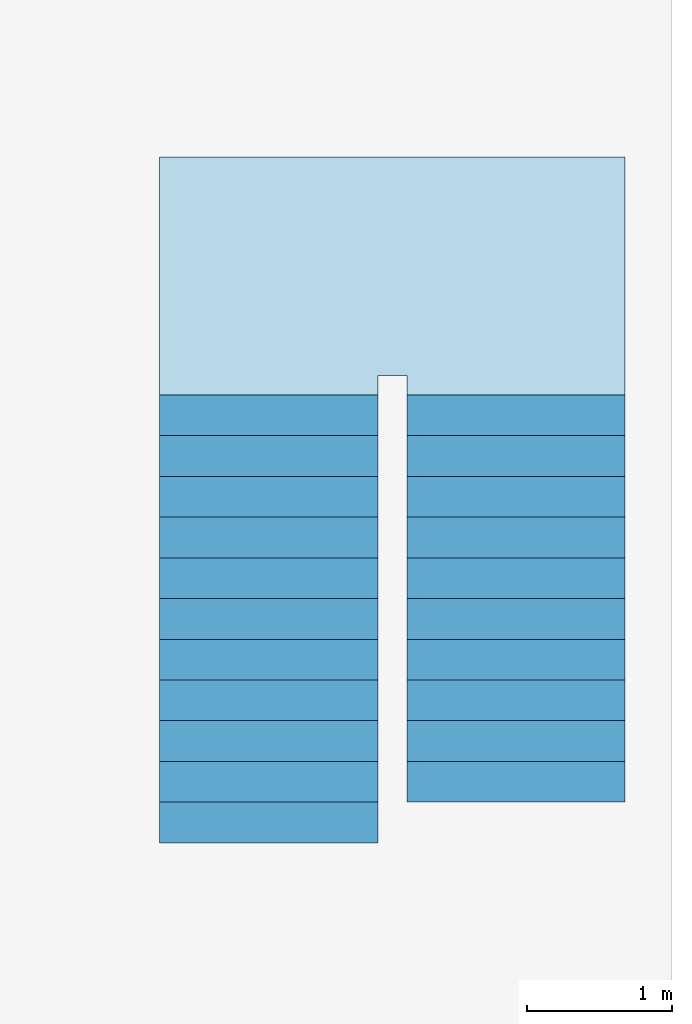
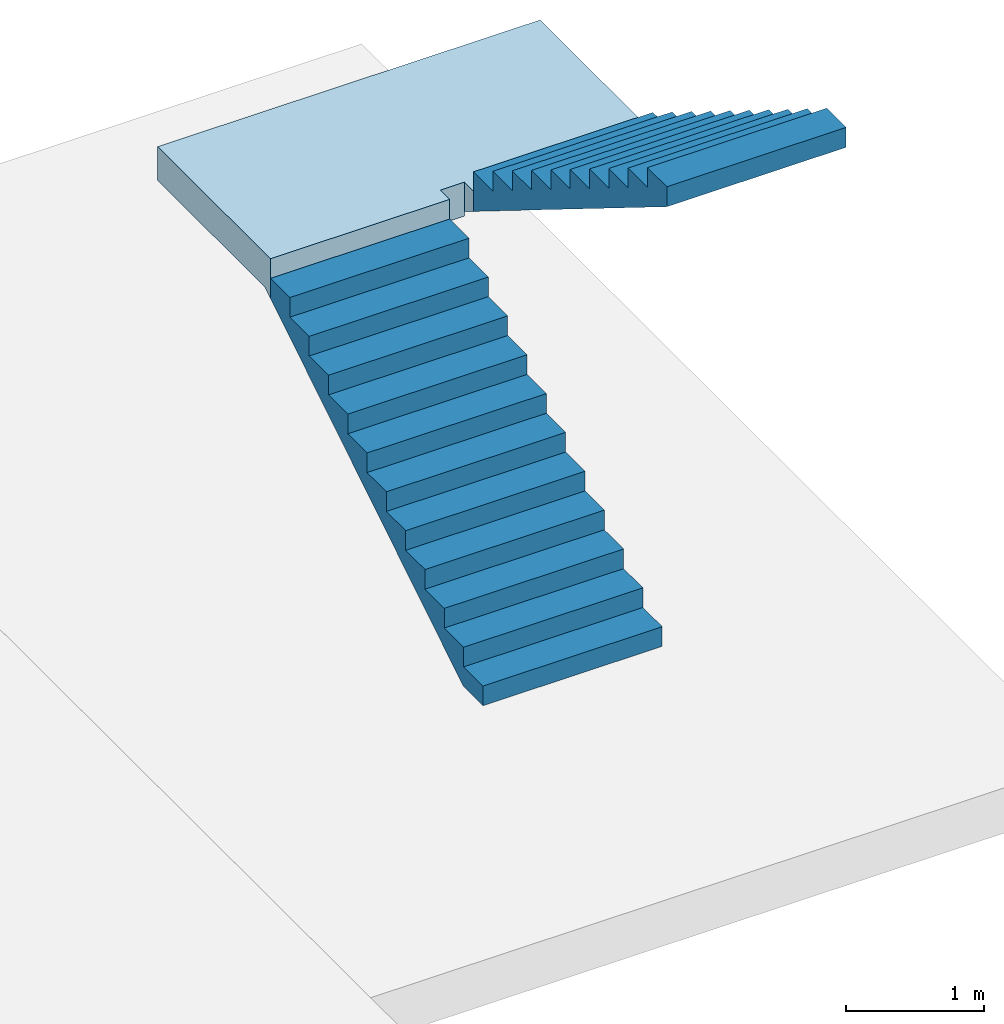
# One storey, part 2 of 2: 2 stair flights, 1 slab, 1 element without a shape of its own.
"""IFC2X3 building model written with IfcOpenShell, lengths in millimetres."""

from ifc_helpers import new_model, entity, si_unit, converted_unit, derived_unit, direction, frame, origin, place, context, subcontext, project, spatial, faceted_brep, material, element, aggregate, save


model = new_model("IFC2X3")

# Units and contexts
model_context = context("Model", 3, precision=0.01, world=origin(), true_north=direction((6.12303176911189e-17, 1.0)))
body_context = subcontext(model_context, "Body", "Model", "MODEL_VIEW")
ifc_project = project(units=[si_unit("LENGTHUNIT", "METRE", prefix="MILLI"), si_unit("AREAUNIT", "SQUARE_METRE"), si_unit("VOLUMEUNIT", "CUBIC_METRE"), converted_unit("PLANEANGLEUNIT", "DEGREE", entity("IfcRatioMeasure", 0.0174532925199433), si_unit("PLANEANGLEUNIT", "RADIAN"), dimensions=[0, 0, 0, 0, 0, 0, 0]), si_unit("MASSUNIT", "GRAM", prefix="KILO"), derived_unit("MASSDENSITYUNIT", [(si_unit("MASSUNIT", "GRAM", prefix="KILO"), 1), (si_unit("LENGTHUNIT", "METRE"), -3)]), si_unit("TIMEUNIT", "SECOND"), si_unit("FREQUENCYUNIT", "HERTZ"), si_unit("THERMODYNAMICTEMPERATUREUNIT", "DEGREE_CELSIUS"), derived_unit("THERMALTRANSMITTANCEUNIT", [(si_unit("MASSUNIT", "GRAM", prefix="KILO"), 1), (si_unit("THERMODYNAMICTEMPERATUREUNIT", "KELVIN"), -1), (si_unit("TIMEUNIT", "SECOND"), -3)]), derived_unit("VOLUMETRICFLOWRATEUNIT", [(si_unit("LENGTHUNIT", "METRE"), 3), (si_unit("TIMEUNIT", "SECOND"), -1)]), si_unit("ELECTRICCURRENTUNIT", "AMPERE"), si_unit("ELECTRICVOLTAGEUNIT", "VOLT"), si_unit("POWERUNIT", "WATT"), si_unit("FORCEUNIT", "NEWTON", prefix="KILO"), si_unit("ILLUMINANCEUNIT", "LUX"), si_unit("LUMINOUSFLUXUNIT", "LUMEN"), si_unit("LUMINOUSINTENSITYUNIT", "CANDELA"), derived_unit("USERDEFINED", [(si_unit("MASSUNIT", "GRAM", prefix="KILO"), -1), (si_unit("LENGTHUNIT", "METRE"), -2), (si_unit("TIMEUNIT", "SECOND"), 3), (si_unit("LUMINOUSFLUXUNIT", "LUMEN"), 1)]), derived_unit("LINEARVELOCITYUNIT", [(si_unit("LENGTHUNIT", "METRE"), 1), (si_unit("TIMEUNIT", "SECOND"), -1)]), si_unit("PRESSUREUNIT", "PASCAL"), derived_unit("USERDEFINED", [(si_unit("LENGTHUNIT", "METRE"), -2), (si_unit("MASSUNIT", "GRAM", prefix="KILO"), 1), (si_unit("TIMEUNIT", "SECOND"), -2)])], contexts=[model_context])

# Site, building, storey
site_placement = place(None, origin())
site = spatial("IfcSite", under=ifc_project, at=site_placement, CompositionType="ELEMENT")
building_placement = place(site_placement, origin())
building = spatial("IfcBuilding", under=site, at=building_placement, CompositionType="ELEMENT")
storey_placement = place(building_placement, origin())
storey = spatial("IfcBuildingStorey", under=building, at=storey_placement, Name="00 Ground level", CompositionType="ELEMENT", Elevation=0.0)

# Stair, slab, stair flights
stair_placement = place(storey_placement, origin())
stair = element("IfcStair", 1, at=stair_placement, inside=storey, Name="Cast-In-Place Stair:Stair", ObjectType="Cast-In-Place Stair:Monolithic Stair", ShapeType="NOTDEFINED")
ifc_material = material(Name="Concrete, Cast In Situ")
slab_placement = place(stair_placement, frame((31263.4900708518, -68480.8241905963, 0.0)))
slab = element("IfcSlab", 2, at=slab_placement, material=ifc_material, Name="Cast-In-Place Stair:Stair:392864 Landing 1", ObjectType="Monolithic Landing:300mm Thickness", PredefinedType="LANDING", context=body_context, shape_type="Brep", body=[
    faceted_brep([(0.0, 0.0, 2086.95652173913), (1500.0, 0.0, 2086.95652173913), (1500.0, 81.2925429905189, 2086.95652173913), (1500.0, 135.0, 2086.95652173913), (1700.0, 135.0, 2086.95652173913), (1700.0, 0.0, 2086.95652173913), (3200.0, 0.0, 2086.95652173913), (3200.0, 198.707457009539, 2086.95652173913), (3200.0, 1635.0, 2086.95652173913), (0.0, 1635.0, 2086.95652173913), (0.0, 81.2925429905189, 2086.95652173913), (0.0, 0.0, 1913.04347826087), (0.0, 0.0, 1736.46425901212), (1500.0, 0.0, 1736.46425901212), (1500.0, 0.0, 1913.04347826087), (1500.0, 81.2925429905189, 1786.95652173913), (1500.0, 135.0, 1786.95652173913), (1700.0, 135.0, 1786.95652173913), (1700.0, 135.0, 1826.52637081337), (3200.0, 0.0, 1910.37730249039), (3200.0, 198.70745700953, 1786.95652173913), (3200.0, 1635.0, 1786.95652173913), (0.0, 1635.0, 1786.95652173913), (0.0, 81.2925429905189, 1786.95652173913), (1700.0, 198.70745700953, 1786.95652173913), (1700.0, 0.0, 1910.37730249039)], [[[0, 1, 2, 3, 4, 5, 6, 7, 8, 9, 10]], [[1, 0, 11, 12, 13, 14]], [[1, 14, 13, 15, 16, 3, 2]], [[4, 3, 16, 17, 18]], [[6, 19, 20, 21, 8, 7]], [[9, 8, 21, 22]], [[12, 11, 0, 10, 9, 22, 23]], [[24, 17, 16, 15, 23, 22, 21, 20]], [[17, 24, 18]], [[23, 15, 13, 12]], [[24, 20, 19, 25, 18]], [[5, 4, 18, 25]], [[6, 5, 25, 19]]]),
])
stair_flight_1_placement = place(stair_placement, frame((31263.4900708518, -71560.8241905963, 0.0)))
stair_flight_1 = element("IfcStairFlight", 3, at=stair_flight_1_placement, material=ifc_material, Name="Cast-In-Place Stair:Stair:392864 Run 1", ObjectType="Monolithic Run:150mm Depth", NumberOfRiser=12, NumberOfTreads=11, RiserHeight=0.57058085130663, TreadLength=0.918635170603675, context=body_context, shape_type="Brep", body=[
    faceted_brep([(0.0, 280.0, 173.913043478261), (0.0, 0.0, 173.913043478261), (1500.0, 0.0, 173.913043478261), (1500.0, 280.0, 173.913043478261), (0.0, 280.0, 0.0), (0.0, 0.0, 0.0), (1500.0, 0.0, 0.0), (1500.0, 280.0, 0.0), (0.0, 560.0, 347.826086956522), (0.0, 280.0, 347.826086956522), (1500.0, 280.0, 347.826086956522), (1500.0, 560.0, 347.826086956522), (0.0, 560.0, 171.246867707768), (0.0, 284.29254299049, 0.0), (1500.0, 284.29254299049, 0.0), (1500.0, 560.0, 171.246867707771), (0.0, 840.0, 521.739130434783), (0.0, 560.0, 521.739130434783), (1500.0, 560.0, 521.739130434783), (1500.0, 840.0, 521.739130434783), (0.0, 840.0, 345.159911186037), (1500.0, 840.0, 345.159911186036), (0.0, 1120.0, 695.652173913044), (0.0, 840.0, 695.652173913044), (1500.0, 840.0, 695.652173913044), (1500.0, 1120.0, 695.652173913044), (0.0, 1120.0, 519.07295466429), (1500.0, 1120.0, 519.072954664289), (0.0, 1400.0, 869.565217391304), (0.0, 1120.0, 869.565217391304), (1500.0, 1120.0, 869.565217391304), (1500.0, 1400.0, 869.565217391304), (0.0, 1400.0, 692.985998142542), (1500.0, 1400.0, 692.985998142553), (0.0, 1680.0, 1043.47826086957), (0.0, 1400.0, 1043.47826086957), (1500.0, 1400.0, 1043.47826086957), (1500.0, 1680.0, 1043.47826086957), (0.0, 1680.0, 866.899041620811), (1500.0, 1680.0, 866.899041620812), (0.0, 1960.0, 1217.39130434783), (0.0, 1680.0, 1217.39130434783), (1500.0, 1680.0, 1217.39130434783), (1500.0, 1960.0, 1217.39130434783), (0.0, 1960.0, 1040.81208509906), (1500.0, 1960.0, 1040.81208509907), (0.0, 2240.0, 1391.30434782609), (0.0, 1960.0, 1391.30434782609), (1500.0, 1960.0, 1391.30434782609), (1500.0, 2240.0, 1391.30434782609), (0.0, 2240.0, 1214.72512857734), (1500.0, 2240.0, 1214.72512857734), (0.0, 2520.0, 1565.21739130435), (0.0, 2240.0, 1565.21739130435), (1500.0, 2240.0, 1565.21739130435), (1500.0, 2520.0, 1565.21739130435), (0.0, 2520.0, 1388.63817205559), (1500.0, 2520.0, 1388.63817205559), (0.0, 2800.0, 1739.13043478261), (0.0, 2520.0, 1739.13043478261), (1500.0, 2520.0, 1739.13043478261), (1500.0, 2800.0, 1739.13043478261), (0.0, 2800.0, 1562.55121553385), (1500.0, 2800.0, 1562.55121553386), (0.0, 3080.0, 1913.04347826087), (0.0, 2800.0, 1913.04347826087), (1500.0, 2800.0, 1913.04347826087), (1500.0, 3080.0, 1913.04347826087), (0.0, 3080.0, 1736.46425901212), (1500.0, 3080.0, 1736.46425901212)], [[[0, 1, 2, 3]], [[1, 0, 4, 5]], [[2, 1, 5, 6]], [[3, 2, 6, 7]], [[8, 9, 10, 11]], [[4, 0, 9, 8, 12, 13]], [[0, 3, 10, 9]], [[3, 7, 14, 15, 11, 10]], [[16, 17, 18, 19]], [[17, 16, 20, 12, 8]], [[8, 11, 18, 17]], [[19, 18, 11, 15, 21]], [[22, 23, 24, 25]], [[23, 22, 26, 20, 16]], [[16, 19, 24, 23]], [[25, 24, 19, 21, 27]], [[28, 29, 30, 31]], [[29, 28, 32, 26, 22]], [[22, 25, 30, 29]], [[31, 30, 25, 27, 33]], [[34, 35, 36, 37]], [[35, 34, 38, 32, 28]], [[28, 31, 36, 35]], [[37, 36, 31, 33, 39]], [[40, 41, 42, 43]], [[41, 40, 44, 38, 34]], [[34, 37, 42, 41]], [[43, 42, 37, 39, 45]], [[46, 47, 48, 49]], [[47, 46, 50, 44, 40]], [[40, 43, 48, 47]], [[49, 48, 43, 45, 51]], [[52, 53, 54, 55]], [[53, 52, 56, 50, 46]], [[46, 49, 54, 53]], [[55, 54, 49, 51, 57]], [[58, 59, 60, 61]], [[59, 58, 62, 56, 52]], [[52, 55, 60, 59]], [[61, 60, 55, 57, 63]], [[64, 65, 66, 67]], [[65, 64, 68, 62, 58]], [[58, 61, 66, 65]], [[67, 66, 61, 63, 69]], [[64, 67, 69, 68]], [[5, 4, 13, 14, 7, 6]], [[14, 13, 12, 20, 26, 32, 38, 44, 50, 56, 62, 68, 69, 63, 57, 51, 45, 39, 33, 27, 21, 15]]]),
])
stair_flight_2_placement = place(stair_placement, frame((32963.4900708518, -71280.8241905964, 0.0)))
stair_flight_2 = element("IfcStairFlight", 4, at=stair_flight_2_placement, material=ifc_material, Name="Cast-In-Place Stair:Stair:392864 Run 2", ObjectType="Monolithic Run:150mm Depth", NumberOfRiser=11, NumberOfTreads=10, RiserHeight=0.57058085130663, TreadLength=0.918635170603675, context=body_context, shape_type="Brep", body=[
    faceted_brep([(1500.0, 2520.0, 2260.86956521739), (1500.0, 2800.0, 2260.86956521739), (0.0, 2800.0, 2260.86956521739), (0.0, 2520.0, 2260.86956521739), (1500.0, 2520.0, 2084.29034596864), (1500.0, 2800.0, 1910.37730249038), (1500.0, 2800.0, 2086.95652173913), (0.0, 2800.0, 1910.37730249038), (0.0, 2800.0, 2086.95652173913), (0.0, 2520.0, 2084.29034596864), (1500.0, 2240.0, 2434.78260869565), (1500.0, 2520.0, 2434.78260869565), (0.0, 2520.0, 2434.78260869565), (0.0, 2240.0, 2434.78260869565), (1500.0, 2240.0, 2258.20338944691), (0.0, 2240.0, 2258.2033894469), (1500.0, 1960.0, 2608.69565217391), (1500.0, 2240.0, 2608.69565217391), (0.0, 2240.0, 2608.69565217391), (0.0, 1960.0, 2608.69565217391), (1500.0, 1960.0, 2432.11643292516), (0.0, 1960.0, 2432.11643292516), (1500.0, 1680.0, 2782.60869565217), (1500.0, 1960.0, 2782.60869565217), (0.0, 1960.0, 2782.60869565217), (0.0, 1680.0, 2782.60869565217), (1500.0, 1680.0, 2606.02947640343), (0.0, 1680.0, 2606.02947640342), (1500.0, 1400.0, 2956.52173913043), (1500.0, 1680.0, 2956.52173913043), (0.0, 1680.0, 2956.52173913043), (0.0, 1400.0, 2956.52173913043), (1500.0, 1400.0, 2779.94251988169), (0.0, 1400.0, 2779.94251988169), (1500.0, 1120.0, 3130.43478260869), (1500.0, 1400.0, 3130.43478260869), (0.0, 1400.0, 3130.43478260869), (0.0, 1120.0, 3130.43478260869), (1500.0, 1120.0, 2953.85556335994), (0.0, 1120.0, 2953.85556335994), (1500.0, 840.0, 3304.34782608696), (1500.0, 1120.0, 3304.34782608696), (0.0, 1120.0, 3304.34782608696), (0.0, 840.0, 3304.34782608696), (1500.0, 840.0, 3127.7686068382), (0.0, 840.0, 3127.7686068382), (1500.0, 560.0, 3478.26086956522), (1500.0, 840.0, 3478.26086956522), (0.0, 840.0, 3478.26086956522), (0.0, 560.0, 3478.26086956522), (1500.0, 560.0, 3301.68165031647), (0.0, 560.0, 3301.68165031646), (1500.0, 280.0, 3652.17391304348), (1500.0, 560.0, 3652.17391304348), (0.0, 560.0, 3652.17391304348), (0.0, 280.0, 3652.17391304348), (1500.0, 280.0, 3475.59469379473), (0.0, 280.0, 3475.59469379472), (1500.0, 0.0, 3826.08695652174), (1500.0, 280.0, 3826.08695652174), (0.0, 280.0, 3826.08695652174), (0.0, 0.0, 3826.08695652174), (1500.0, 0.0, 3649.50773727299), (0.0, 0.0, 3649.50773727299)], [[[0, 1, 2, 3]], [[1, 0, 4, 5, 6]], [[2, 1, 6, 5, 7, 8]], [[3, 2, 8, 7, 9]], [[10, 11, 12, 13]], [[11, 10, 14, 4, 0]], [[12, 11, 0, 3]], [[13, 12, 3, 9, 15]], [[16, 17, 18, 19]], [[17, 16, 20, 14, 10]], [[18, 17, 10, 13]], [[19, 18, 13, 15, 21]], [[22, 23, 24, 25]], [[23, 22, 26, 20, 16]], [[24, 23, 16, 19]], [[25, 24, 19, 21, 27]], [[28, 29, 30, 31]], [[29, 28, 32, 26, 22]], [[30, 29, 22, 25]], [[31, 30, 25, 27, 33]], [[34, 35, 36, 37]], [[35, 34, 38, 32, 28]], [[36, 35, 28, 31]], [[37, 36, 31, 33, 39]], [[40, 41, 42, 43]], [[41, 40, 44, 38, 34]], [[42, 41, 34, 37]], [[43, 42, 37, 39, 45]], [[46, 47, 48, 49]], [[47, 46, 50, 44, 40]], [[48, 47, 40, 43]], [[49, 48, 43, 45, 51]], [[52, 53, 54, 55]], [[53, 52, 56, 50, 46]], [[54, 53, 46, 49]], [[55, 54, 49, 51, 57]], [[58, 59, 60, 61]], [[59, 58, 62, 56, 52]], [[60, 59, 52, 55]], [[61, 60, 55, 57, 63]], [[58, 61, 63, 62]], [[5, 4, 14, 20, 26, 32, 38, 44, 50, 56, 62, 63, 57, 51, 45, 39, 33, 27, 21, 15, 9, 7]]]),
])
aggregate(stair, [stair_flight_1, stair_flight_2, slab])

save(model, "model.ifc")
